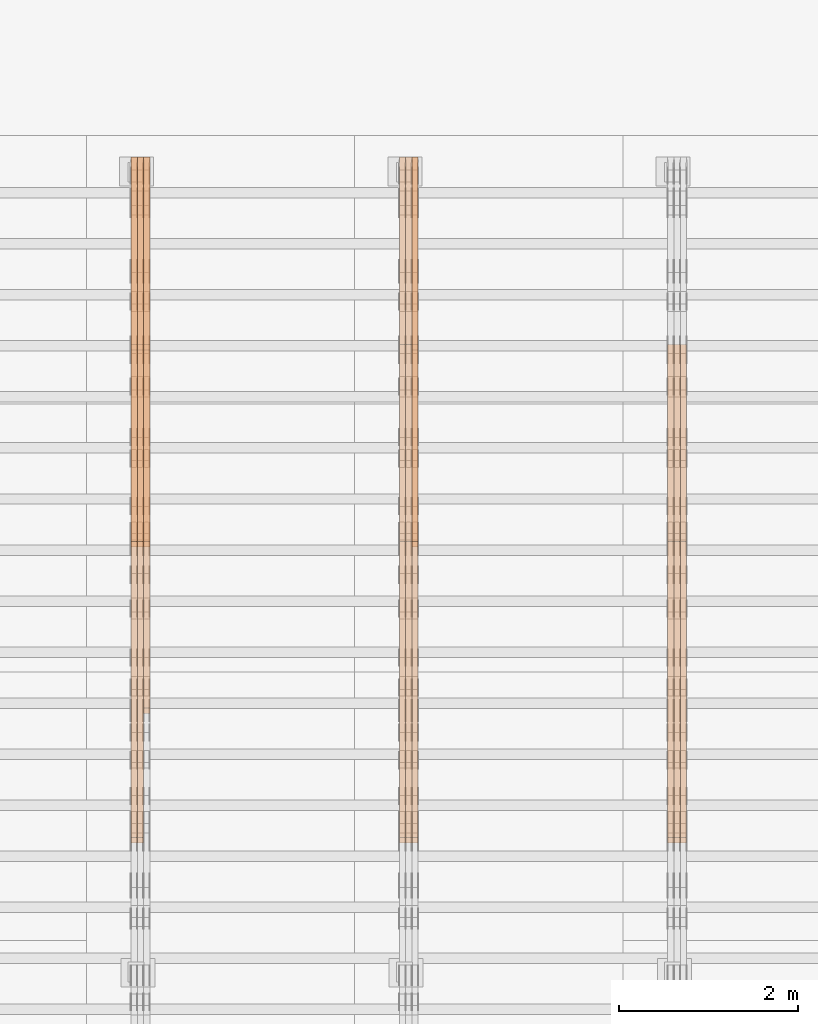
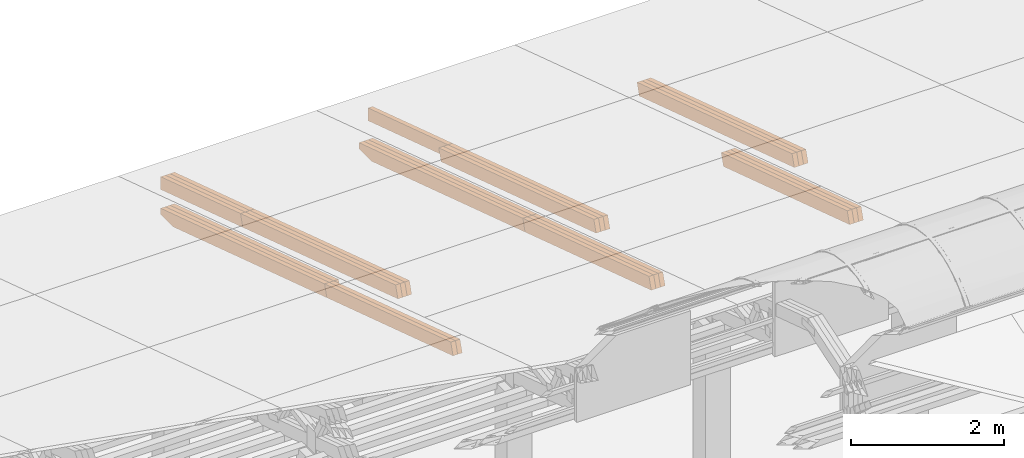
# One storey, part 23 of 385: 27 proxies.
"""IFC2X3 building model written with IfcOpenShell, lengths in millimetres."""

from ifc_helpers import new_model, entity, si_unit, converted_unit, derived_unit, direction, frame, origin, place, context, subcontext, project, spatial, polyline, outline, extrude, source, transform, mapped, material, type_object, type_shapes, element, save


model = new_model("IFC2X3")

# Units and contexts
model_context = context("Model", 3, precision=0.01, world=origin(), true_north=direction((6.12303176911189e-17, 1.0)))
body_context = subcontext(model_context, "Body", "Model", "MODEL_VIEW")
ifc_project = project(units=[si_unit("LENGTHUNIT", "METRE", prefix="MILLI"), si_unit("AREAUNIT", "SQUARE_METRE"), si_unit("VOLUMEUNIT", "CUBIC_METRE"), converted_unit("PLANEANGLEUNIT", "DEGREE", entity("IfcRatioMeasure", 0.0174532925199433), si_unit("PLANEANGLEUNIT", "RADIAN"), dimensions=[0, 0, 0, 0, 0, 0, 0]), si_unit("MASSUNIT", "GRAM", prefix="KILO"), derived_unit("MASSDENSITYUNIT", [(si_unit("MASSUNIT", "GRAM", prefix="KILO"), 1), (si_unit("LENGTHUNIT", "METRE"), -3)]), si_unit("TIMEUNIT", "SECOND"), si_unit("FREQUENCYUNIT", "HERTZ"), si_unit("THERMODYNAMICTEMPERATUREUNIT", "DEGREE_CELSIUS"), derived_unit("THERMALTRANSMITTANCEUNIT", [(si_unit("MASSUNIT", "GRAM", prefix="KILO"), 1), (si_unit("THERMODYNAMICTEMPERATUREUNIT", "KELVIN"), -1), (si_unit("TIMEUNIT", "SECOND"), -3)]), derived_unit("VOLUMETRICFLOWRATEUNIT", [(si_unit("LENGTHUNIT", "METRE"), 3), (si_unit("TIMEUNIT", "SECOND"), -1)]), si_unit("ELECTRICCURRENTUNIT", "AMPERE"), si_unit("ELECTRICVOLTAGEUNIT", "VOLT"), si_unit("POWERUNIT", "WATT"), si_unit("FORCEUNIT", "NEWTON", prefix="KILO"), si_unit("ILLUMINANCEUNIT", "LUX"), si_unit("LUMINOUSFLUXUNIT", "LUMEN"), si_unit("LUMINOUSINTENSITYUNIT", "CANDELA"), derived_unit("USERDEFINED", [(si_unit("MASSUNIT", "GRAM", prefix="KILO"), -1), (si_unit("LENGTHUNIT", "METRE"), -2), (si_unit("TIMEUNIT", "SECOND"), 3), (si_unit("LUMINOUSFLUXUNIT", "LUMEN"), 1)]), derived_unit("LINEARVELOCITYUNIT", [(si_unit("LENGTHUNIT", "METRE"), 1), (si_unit("TIMEUNIT", "SECOND"), -1)]), si_unit("PRESSUREUNIT", "PASCAL"), derived_unit("USERDEFINED", [(si_unit("LENGTHUNIT", "METRE"), -2), (si_unit("MASSUNIT", "GRAM", prefix="KILO"), 1), (si_unit("TIMEUNIT", "SECOND"), -2)])], contexts=[model_context])

# Site, building, storey
site_placement = place(None, origin())
site = spatial("IfcSite", under=ifc_project, at=site_placement, CompositionType="ELEMENT")
building_placement = place(site_placement, origin())
building = spatial("IfcBuilding", under=site, at=building_placement, CompositionType="ELEMENT")
storey_placement = place(building_placement, origin())
storey = spatial("IfcBuildingStorey", under=building, at=storey_placement, Name="Default", CompositionType="ELEMENT", Elevation=0.0)

# Proxies
ifc_material_1 = material(Name="IfcSurfaceStyle #352509")
building_element_proxy_type_1 = type_object("IfcBuildingElementProxyType", Name="T1-T2 352507", PredefinedType="NOTDEFINED", material=ifc_material_1)
shared_shape_1 = source(origin(), body_context, "Body", "SweptSolid", [
    extrude(outline(polyline([(-2137.04373183812, -97.5000250291418), (2137.04394104036, -97.5000250291418), (2137.04396402965, 97.5000250291418), (-2137.04417323189, 97.5000250291418), (-2137.04373183812, -97.5000250291418)])), frame((2137.04396402965, 97.5001541485632, 0.0), z_axis=(0.0, 0.0, 1.0), x_axis=(-1.0, 0.0, 0.0)), (0.0, 0.0, 1.0), 69.9999999999997),
])
type_shapes(building_element_proxy_type_1, [shared_shape_1])
proxy_1_placement = place(building_placement, frame((30385.0, 24344.7841397874, 1095.2368156767), z_axis=(-1.0, 0.0, 0.0), x_axis=(0.0, -0.951056516295154, 0.309016994374948)))
element("IfcBuildingElementProxy", 1, at=proxy_1_placement, inside=storey, type_object=building_element_proxy_type_1, material=ifc_material_1, Name="T1-T2", context=body_context, shape_type="MappedRepresentation", body=[
    mapped(shared_shape_1, transform((0.0, 0.0, 0.0), scale=1.0)),
])
ifc_material_2 = material(Name="IfcSurfaceStyle #352452")
building_element_proxy_type_2 = type_object("IfcBuildingElementProxyType", Name="T1-T2 352450", PredefinedType="NOTDEFINED", material=ifc_material_2)
shared_shape_2 = source(origin(), body_context, "Body", "SweptSolid", [
    extrude(outline(polyline([(-2137.04373183812, -97.5000250291418), (2137.04394104036, -97.5000250291418), (2137.04396402965, 97.5000250291418), (-2137.04417323189, 97.5000250291418), (-2137.04373183812, -97.5000250291418)])), frame((2137.04396402965, 97.5001541485632, 0.0), z_axis=(0.0, 0.0, 1.0), x_axis=(-1.0, 0.0, 0.0)), (0.0, 0.0, 1.0), 69.9999999999997),
])
type_shapes(building_element_proxy_type_2, [shared_shape_2])
proxy_2_placement = place(building_placement, frame((30315.0, 24344.7841397874, 1095.2368156767), z_axis=(-1.0, 0.0, 0.0), x_axis=(0.0, -0.951056516295154, 0.309016994374948)))
element("IfcBuildingElementProxy", 2, at=proxy_2_placement, inside=storey, type_object=building_element_proxy_type_2, material=ifc_material_2, Name="T1-T2", context=body_context, shape_type="MappedRepresentation", body=[
    mapped(shared_shape_2, transform((0.0, 0.0, 0.0), scale=1.0)),
])
ifc_material_3 = material(Name="IfcSurfaceStyle #352395")
building_element_proxy_type_3 = type_object("IfcBuildingElementProxyType", Name="T1-T2 352393", PredefinedType="NOTDEFINED", material=ifc_material_3)
shared_shape_3 = source(origin(), body_context, "Body", "SweptSolid", [
    extrude(outline(polyline([(-2137.04373183812, -97.5000250291418), (2137.04394104036, -97.5000250291418), (2137.04396402965, 97.5000250291418), (-2137.04417323189, 97.5000250291418), (-2137.04373183812, -97.5000250291418)])), frame((2137.04396402965, 97.5001541485632, 0.0), z_axis=(0.0, 0.0, 1.0), x_axis=(-1.0, 0.0, 0.0)), (0.0, 0.0, 1.0), 69.9999999999997),
])
type_shapes(building_element_proxy_type_3, [shared_shape_3])
proxy_3_placement = place(building_placement, frame((30245.0, 24344.7841397874, 1095.2368156767), z_axis=(-1.0, 0.0, 0.0), x_axis=(0.0, -0.951056516295154, 0.309016994374948)))
element("IfcBuildingElementProxy", 3, at=proxy_3_placement, inside=storey, type_object=building_element_proxy_type_3, material=ifc_material_3, Name="T1-T2", context=body_context, shape_type="MappedRepresentation", body=[
    mapped(shared_shape_3, transform((0.0, 0.0, 0.0), scale=1.0)),
])
ifc_material_4 = material(Name="IfcSurfaceStyle #351114")
building_element_proxy_type_4 = type_object("IfcBuildingElementProxyType", Name="T1-B2 351112", PredefinedType="NOTDEFINED", material=ifc_material_4)
shared_shape_4 = source(origin(), body_context, "Body", "SweptSolid", [
    extrude(outline(polyline([(-1738.61933402934, -97.4999466901035), (1738.6190788485, -97.4999466901035), (1738.6191018378, 97.4999466901035), (-1738.61884665697, 97.4999466901035), (-1738.61933402934, -97.4999466901035)])), frame((1738.6191018378, 97.4999528847471, 0.0), z_axis=(0.0, 0.0, 1.0), x_axis=(-1.0, 0.0, 0.0)), (0.0, 0.0, 1.0), 69.9999999999998),
])
type_shapes(building_element_proxy_type_4, [shared_shape_4])
proxy_4_placement = place(building_placement, frame((30385.0, 22140.4521465233, 1306.03026754604), z_axis=(-1.0, 0.0, 0.0), x_axis=(0.0, -0.951056516295124, 0.309016994375039)))
element("IfcBuildingElementProxy", 4, at=proxy_4_placement, inside=storey, type_object=building_element_proxy_type_4, material=ifc_material_4, Name="T1-B2", context=body_context, shape_type="MappedRepresentation", body=[
    mapped(shared_shape_4, transform((0.0, 0.0, 0.0), scale=1.0)),
])
ifc_material_5 = material(Name="IfcSurfaceStyle #351057")
building_element_proxy_type_5 = type_object("IfcBuildingElementProxyType", Name="T1-B2 351055", PredefinedType="NOTDEFINED", material=ifc_material_5)
shared_shape_5 = source(origin(), body_context, "Body", "SweptSolid", [
    extrude(outline(polyline([(-1738.61933402934, -97.4999466901035), (1738.6190788485, -97.4999466901035), (1738.6191018378, 97.4999466901035), (-1738.61884665697, 97.4999466901035), (-1738.61933402934, -97.4999466901035)])), frame((1738.6191018378, 97.4999528847471, 0.0), z_axis=(0.0, 0.0, 1.0), x_axis=(-1.0, 0.0, 0.0)), (0.0, 0.0, 1.0), 69.9999999999998),
])
type_shapes(building_element_proxy_type_5, [shared_shape_5])
proxy_5_placement = place(building_placement, frame((30315.0, 22140.4521465233, 1306.03026754604), z_axis=(-1.0, 0.0, 0.0), x_axis=(0.0, -0.951056516295124, 0.309016994375039)))
element("IfcBuildingElementProxy", 5, at=proxy_5_placement, inside=storey, type_object=building_element_proxy_type_5, material=ifc_material_5, Name="T1-B2", context=body_context, shape_type="MappedRepresentation", body=[
    mapped(shared_shape_5, transform((0.0, 0.0, 0.0), scale=1.0)),
])
ifc_material_6 = material(Name="IfcSurfaceStyle #351000")
building_element_proxy_type_6 = type_object("IfcBuildingElementProxyType", Name="T1-B2 350998", PredefinedType="NOTDEFINED", material=ifc_material_6)
shared_shape_6 = source(origin(), body_context, "Body", "SweptSolid", [
    extrude(outline(polyline([(-1738.61933402934, -97.4999466901035), (1738.6190788485, -97.4999466901035), (1738.6191018378, 97.4999466901035), (-1738.61884665697, 97.4999466901035), (-1738.61933402934, -97.4999466901035)])), frame((1738.6191018378, 97.4999528847471, 0.0), z_axis=(0.0, 0.0, 1.0), x_axis=(-1.0, 0.0, 0.0)), (0.0, 0.0, 1.0), 69.9999999999998),
])
type_shapes(building_element_proxy_type_6, [shared_shape_6])
proxy_6_placement = place(building_placement, frame((30245.0, 22140.4521465233, 1306.03026754604), z_axis=(-1.0, 0.0, 0.0), x_axis=(0.0, -0.951056516295124, 0.309016994375039)))
element("IfcBuildingElementProxy", 6, at=proxy_6_placement, inside=storey, type_object=building_element_proxy_type_6, material=ifc_material_6, Name="T1-B2", context=body_context, shape_type="MappedRepresentation", body=[
    mapped(shared_shape_6, transform((0.0, 0.0, 0.0), scale=1.0)),
])
ifc_material_7 = material(Name="IfcSurfaceStyle #318077")
building_element_proxy_type_7 = type_object("IfcBuildingElementProxyType", Name="T1-T2 318075", PredefinedType="NOTDEFINED", material=ifc_material_7)
shared_shape_7 = source(origin(), body_context, "Body", "SweptSolid", [
    extrude(outline(polyline([(-2137.04373183812, -97.5000250291418), (2137.04394104036, -97.5000250291418), (2137.04396402965, 97.5000250291418), (-2137.04417323189, 97.5000250291418), (-2137.04373183812, -97.5000250291418)])), frame((2137.04396402965, 97.5001541485632, 0.0), z_axis=(0.0, 0.0, 1.0), x_axis=(-1.0, 0.0, 0.0)), (0.0, 0.0, 1.0), 69.9999999999997),
])
type_shapes(building_element_proxy_type_7, [shared_shape_7])
proxy_7_placement = place(building_placement, frame((27385.0, 24344.7841397874, 1095.2368156767), z_axis=(-1.0, 0.0, 0.0), x_axis=(0.0, -0.951056516295154, 0.309016994374948)))
element("IfcBuildingElementProxy", 7, at=proxy_7_placement, inside=storey, type_object=building_element_proxy_type_7, material=ifc_material_7, Name="T1-T2", context=body_context, shape_type="MappedRepresentation", body=[
    mapped(shared_shape_7, transform((0.0, 0.0, 0.0), scale=1.0)),
])
ifc_material_8 = material(Name="IfcSurfaceStyle #318020")
building_element_proxy_type_8 = type_object("IfcBuildingElementProxyType", Name="T1-T2 318018", PredefinedType="NOTDEFINED", material=ifc_material_8)
shared_shape_8 = source(origin(), body_context, "Body", "SweptSolid", [
    extrude(outline(polyline([(-2137.04373183812, -97.5000250291418), (2137.04394104036, -97.5000250291418), (2137.04396402965, 97.5000250291418), (-2137.04417323189, 97.5000250291418), (-2137.04373183812, -97.5000250291418)])), frame((2137.04396402965, 97.5001541485632, 0.0), z_axis=(0.0, 0.0, 1.0), x_axis=(-1.0, 0.0, 0.0)), (0.0, 0.0, 1.0), 69.9999999999997),
])
type_shapes(building_element_proxy_type_8, [shared_shape_8])
proxy_8_placement = place(building_placement, frame((27315.0, 24344.7841397874, 1095.2368156767), z_axis=(-1.0, 0.0, 0.0), x_axis=(0.0, -0.951056516295154, 0.309016994374948)))
element("IfcBuildingElementProxy", 8, at=proxy_8_placement, inside=storey, type_object=building_element_proxy_type_8, material=ifc_material_8, Name="T1-T2", context=body_context, shape_type="MappedRepresentation", body=[
    mapped(shared_shape_8, transform((0.0, 0.0, 0.0), scale=1.0)),
])
ifc_material_9 = material(Name="IfcSurfaceStyle #317963")
building_element_proxy_type_9 = type_object("IfcBuildingElementProxyType", Name="T1-T2 317961", PredefinedType="NOTDEFINED", material=ifc_material_9)
shared_shape_9 = source(origin(), body_context, "Body", "SweptSolid", [
    extrude(outline(polyline([(-2137.04373183812, -97.5000250291418), (2137.04394104036, -97.5000250291418), (2137.04396402965, 97.5000250291418), (-2137.04417323189, 97.5000250291418), (-2137.04373183812, -97.5000250291418)])), frame((2137.04396402965, 97.5001541485632, 0.0), z_axis=(0.0, 0.0, 1.0), x_axis=(-1.0, 0.0, 0.0)), (0.0, 0.0, 1.0), 69.9999999999997),
])
type_shapes(building_element_proxy_type_9, [shared_shape_9])
proxy_9_placement = place(building_placement, frame((27245.0, 24344.7841397874, 1095.2368156767), z_axis=(-1.0, 0.0, 0.0), x_axis=(0.0, -0.951056516295154, 0.309016994374948)))
element("IfcBuildingElementProxy", 9, at=proxy_9_placement, inside=storey, type_object=building_element_proxy_type_9, material=ifc_material_9, Name="T1-T2", context=body_context, shape_type="MappedRepresentation", body=[
    mapped(shared_shape_9, transform((0.0, 0.0, 0.0), scale=1.0)),
])
ifc_material_10 = material(Name="IfcSurfaceStyle #317906")
building_element_proxy_type_10 = type_object("IfcBuildingElementProxyType", Name="T1-T3 317904", PredefinedType="NOTDEFINED", material=ifc_material_10)
shared_shape_10 = source(origin(), body_context, "Body", "SweptSolid", [
    extrude(outline(polyline([(-1117.22419189679, -97.5000115568039), (1085.54451125458, -97.5000115568039), (1148.90384954971, 97.5000115568039), (-1117.2241689075, 97.5000115568039), (-1117.22419189679, -97.5000115568039)])), frame((1148.90385201956, 97.5000191595882, 0.0), z_axis=(0.0, 0.0, 1.0), x_axis=(-1.0, 0.0, 0.0)), (0.0, 0.0, 1.0), 69.9999999999999),
])
type_shapes(building_element_proxy_type_10, [shared_shape_10])
proxy_10_placement = place(building_placement, frame((27385.0, 26500.0, 394.964866273674), z_axis=(-1.0, 0.0, 0.0), x_axis=(0.0, -0.951056516295154, 0.309016994374948)))
element("IfcBuildingElementProxy", 10, at=proxy_10_placement, inside=storey, type_object=building_element_proxy_type_10, material=ifc_material_10, Name="T1-T3", context=body_context, shape_type="MappedRepresentation", body=[
    mapped(shared_shape_10, transform((0.0, 0.0, 0.0), scale=1.0)),
])
ifc_material_11 = material(Name="IfcSurfaceStyle #316682")
building_element_proxy_type_11 = type_object("IfcBuildingElementProxyType", Name="T1-B2 316680", PredefinedType="NOTDEFINED", material=ifc_material_11)
shared_shape_11 = source(origin(), body_context, "Body", "SweptSolid", [
    extrude(outline(polyline([(-1738.61933402934, -97.4999466901035), (1738.6190788485, -97.4999466901035), (1738.6191018378, 97.4999466901035), (-1738.61884665697, 97.4999466901035), (-1738.61933402934, -97.4999466901035)])), frame((1738.6191018378, 97.4999528847471, 0.0), z_axis=(0.0, 0.0, 1.0), x_axis=(-1.0, 0.0, 0.0)), (0.0, 0.0, 1.0), 69.9999999999998),
])
type_shapes(building_element_proxy_type_11, [shared_shape_11])
proxy_11_placement = place(building_placement, frame((27385.0, 22140.4521465233, 1306.03026754604), z_axis=(-1.0, 0.0, 0.0), x_axis=(0.0, -0.951056516295124, 0.309016994375039)))
element("IfcBuildingElementProxy", 11, at=proxy_11_placement, inside=storey, type_object=building_element_proxy_type_11, material=ifc_material_11, Name="T1-B2", context=body_context, shape_type="MappedRepresentation", body=[
    mapped(shared_shape_11, transform((0.0, 0.0, 0.0), scale=1.0)),
])
ifc_material_12 = material(Name="IfcSurfaceStyle #316625")
building_element_proxy_type_12 = type_object("IfcBuildingElementProxyType", Name="T1-B2 316623", PredefinedType="NOTDEFINED", material=ifc_material_12)
shared_shape_12 = source(origin(), body_context, "Body", "SweptSolid", [
    extrude(outline(polyline([(-1738.61933402934, -97.4999466901035), (1738.6190788485, -97.4999466901035), (1738.6191018378, 97.4999466901035), (-1738.61884665697, 97.4999466901035), (-1738.61933402934, -97.4999466901035)])), frame((1738.6191018378, 97.4999528847471, 0.0), z_axis=(0.0, 0.0, 1.0), x_axis=(-1.0, 0.0, 0.0)), (0.0, 0.0, 1.0), 69.9999999999998),
])
type_shapes(building_element_proxy_type_12, [shared_shape_12])
proxy_12_placement = place(building_placement, frame((27315.0, 22140.4521465233, 1306.03026754604), z_axis=(-1.0, 0.0, 0.0), x_axis=(0.0, -0.951056516295124, 0.309016994375039)))
element("IfcBuildingElementProxy", 12, at=proxy_12_placement, inside=storey, type_object=building_element_proxy_type_12, material=ifc_material_12, Name="T1-B2", context=body_context, shape_type="MappedRepresentation", body=[
    mapped(shared_shape_12, transform((0.0, 0.0, 0.0), scale=1.0)),
])
ifc_material_13 = material(Name="IfcSurfaceStyle #316568")
building_element_proxy_type_13 = type_object("IfcBuildingElementProxyType", Name="T1-B2 316566", PredefinedType="NOTDEFINED", material=ifc_material_13)
shared_shape_13 = source(origin(), body_context, "Body", "SweptSolid", [
    extrude(outline(polyline([(-1738.61933402934, -97.4999466901035), (1738.6190788485, -97.4999466901035), (1738.6191018378, 97.4999466901035), (-1738.61884665697, 97.4999466901035), (-1738.61933402934, -97.4999466901035)])), frame((1738.6191018378, 97.4999528847471, 0.0), z_axis=(0.0, 0.0, 1.0), x_axis=(-1.0, 0.0, 0.0)), (0.0, 0.0, 1.0), 69.9999999999998),
])
type_shapes(building_element_proxy_type_13, [shared_shape_13])
proxy_13_placement = place(building_placement, frame((27245.0, 22140.4521465233, 1306.03026754604), z_axis=(-1.0, 0.0, 0.0), x_axis=(0.0, -0.951056516295124, 0.309016994375039)))
element("IfcBuildingElementProxy", 13, at=proxy_13_placement, inside=storey, type_object=building_element_proxy_type_13, material=ifc_material_13, Name="T1-B2", context=body_context, shape_type="MappedRepresentation", body=[
    mapped(shared_shape_13, transform((0.0, 0.0, 0.0), scale=1.0)),
])
ifc_material_14 = material(Name="IfcSurfaceStyle #316511")
building_element_proxy_type_14 = type_object("IfcBuildingElementProxyType", Name="T1-B1 316509", PredefinedType="NOTDEFINED", material=ifc_material_14)
shared_shape_14 = source(origin(), body_context, "Body", "SweptSolid", [
    extrude(outline(polyline([(-2659.34106034305, -95.9868650736445), (1861.19950396595, -95.9868650736445), (1890.42090463564, -6.05260867570997), (1567.0616890952, 99.0131694114995), (-2659.34103735375, 99.0131694114995), (-2659.34106034305, -95.9868650736445)])), frame((1890.42090463564, 99.013169411504, 0.0), z_axis=(0.0, 0.0, 1.0), x_axis=(-1.0, 0.0, 0.0)), (0.0, 0.0, 1.0), 69.9999999999997),
])
type_shapes(building_element_proxy_type_14, [shared_shape_14])
proxy_14_placement = place(building_placement, frame((27385.0, 26467.5328890438, -99.9234928894624), z_axis=(-1.0, 0.0, 0.0), x_axis=(0.0, -0.951056516295124, 0.309016994375039)))
element("IfcBuildingElementProxy", 14, at=proxy_14_placement, inside=storey, type_object=building_element_proxy_type_14, material=ifc_material_14, Name="T1-B1", context=body_context, shape_type="MappedRepresentation", body=[
    mapped(shared_shape_14, transform((0.0, 0.0, 0.0), scale=1.0)),
])
ifc_material_15 = material(Name="IfcSurfaceStyle #316445")
building_element_proxy_type_15 = type_object("IfcBuildingElementProxyType", Name="T1-B1 316443", PredefinedType="NOTDEFINED", material=ifc_material_15)
shared_shape_15 = source(origin(), body_context, "Body", "SweptSolid", [
    extrude(outline(polyline([(-2659.34106034305, -95.9868650736445), (1861.19950396595, -95.9868650736445), (1890.42090463564, -6.05260867570997), (1567.0616890952, 99.0131694114995), (-2659.34103735375, 99.0131694114995), (-2659.34106034305, -95.9868650736445)])), frame((1890.42090463564, 99.013169411504, 0.0), z_axis=(0.0, 0.0, 1.0), x_axis=(-1.0, 0.0, 0.0)), (0.0, 0.0, 1.0), 69.9999999999997),
])
type_shapes(building_element_proxy_type_15, [shared_shape_15])
proxy_15_placement = place(building_placement, frame((27315.0, 26467.5328890438, -99.9234928894624), z_axis=(-1.0, 0.0, 0.0), x_axis=(0.0, -0.951056516295124, 0.309016994375039)))
element("IfcBuildingElementProxy", 15, at=proxy_15_placement, inside=storey, type_object=building_element_proxy_type_15, material=ifc_material_15, Name="T1-B1", context=body_context, shape_type="MappedRepresentation", body=[
    mapped(shared_shape_15, transform((0.0, 0.0, 0.0), scale=1.0)),
])
ifc_material_16 = material(Name="IfcSurfaceStyle #316379")
building_element_proxy_type_16 = type_object("IfcBuildingElementProxyType", Name="T1-B1 316377", PredefinedType="NOTDEFINED", material=ifc_material_16)
shared_shape_16 = source(origin(), body_context, "Body", "SweptSolid", [
    extrude(outline(polyline([(-2659.34106034305, -95.9868650736445), (1861.19950396595, -95.9868650736445), (1890.42090463564, -6.05260867570997), (1567.0616890952, 99.0131694114995), (-2659.34103735375, 99.0131694114995), (-2659.34106034305, -95.9868650736445)])), frame((1890.42090463564, 99.013169411504, 0.0), z_axis=(0.0, 0.0, 1.0), x_axis=(-1.0, 0.0, 0.0)), (0.0, 0.0, 1.0), 69.9999999999997),
])
type_shapes(building_element_proxy_type_16, [shared_shape_16])
proxy_16_placement = place(building_placement, frame((27245.0, 26467.5328890438, -99.9234928894624), z_axis=(-1.0, 0.0, 0.0), x_axis=(0.0, -0.951056516295124, 0.309016994375039)))
element("IfcBuildingElementProxy", 16, at=proxy_16_placement, inside=storey, type_object=building_element_proxy_type_16, material=ifc_material_16, Name="T1-B1", context=body_context, shape_type="MappedRepresentation", body=[
    mapped(shared_shape_16, transform((0.0, 0.0, 0.0), scale=1.0)),
])
ifc_material_17 = material(Name="IfcSurfaceStyle #283645")
building_element_proxy_type_17 = type_object("IfcBuildingElementProxyType", Name="T1-T2 283643", PredefinedType="NOTDEFINED", material=ifc_material_17)
shared_shape_17 = source(origin(), body_context, "Body", "SweptSolid", [
    extrude(outline(polyline([(-2137.04373183812, -97.5000250291418), (2137.04394104036, -97.5000250291418), (2137.04396402965, 97.5000250291418), (-2137.04417323189, 97.5000250291418), (-2137.04373183812, -97.5000250291418)])), frame((2137.04396402965, 97.5001541485632, 0.0), z_axis=(0.0, 0.0, 1.0), x_axis=(-1.0, 0.0, 0.0)), (0.0, 0.0, 1.0), 69.9999999999997),
])
type_shapes(building_element_proxy_type_17, [shared_shape_17])
proxy_17_placement = place(building_placement, frame((24385.0, 24344.7841397874, 1095.2368156767), z_axis=(-1.0, 0.0, 0.0), x_axis=(0.0, -0.951056516295154, 0.309016994374948)))
element("IfcBuildingElementProxy", 17, at=proxy_17_placement, inside=storey, type_object=building_element_proxy_type_17, material=ifc_material_17, Name="T1-T2", context=body_context, shape_type="MappedRepresentation", body=[
    mapped(shared_shape_17, transform((0.0, 0.0, 0.0), scale=1.0)),
])
ifc_material_18 = material(Name="IfcSurfaceStyle #283588")
building_element_proxy_type_18 = type_object("IfcBuildingElementProxyType", Name="T1-T2 283586", PredefinedType="NOTDEFINED", material=ifc_material_18)
shared_shape_18 = source(origin(), body_context, "Body", "SweptSolid", [
    extrude(outline(polyline([(-2137.04373183812, -97.5000250291418), (2137.04394104036, -97.5000250291418), (2137.04396402965, 97.5000250291418), (-2137.04417323189, 97.5000250291418), (-2137.04373183812, -97.5000250291418)])), frame((2137.04396402965, 97.5001541485632, 0.0), z_axis=(0.0, 0.0, 1.0), x_axis=(-1.0, 0.0, 0.0)), (0.0, 0.0, 1.0), 69.9999999999997),
])
type_shapes(building_element_proxy_type_18, [shared_shape_18])
proxy_18_placement = place(building_placement, frame((24315.0, 24344.7841397874, 1095.2368156767), z_axis=(-1.0, 0.0, 0.0), x_axis=(0.0, -0.951056516295154, 0.309016994374948)))
element("IfcBuildingElementProxy", 18, at=proxy_18_placement, inside=storey, type_object=building_element_proxy_type_18, material=ifc_material_18, Name="T1-T2", context=body_context, shape_type="MappedRepresentation", body=[
    mapped(shared_shape_18, transform((0.0, 0.0, 0.0), scale=1.0)),
])
ifc_material_19 = material(Name="IfcSurfaceStyle #283531")
building_element_proxy_type_19 = type_object("IfcBuildingElementProxyType", Name="T1-T2 283529", PredefinedType="NOTDEFINED", material=ifc_material_19)
shared_shape_19 = source(origin(), body_context, "Body", "SweptSolid", [
    extrude(outline(polyline([(-2137.04373183812, -97.5000250291418), (2137.04394104036, -97.5000250291418), (2137.04396402965, 97.5000250291418), (-2137.04417323189, 97.5000250291418), (-2137.04373183812, -97.5000250291418)])), frame((2137.04396402965, 97.5001541485632, 0.0), z_axis=(0.0, 0.0, 1.0), x_axis=(-1.0, 0.0, 0.0)), (0.0, 0.0, 1.0), 69.9999999999997),
])
type_shapes(building_element_proxy_type_19, [shared_shape_19])
proxy_19_placement = place(building_placement, frame((24245.0, 24344.7841397874, 1095.2368156767), z_axis=(-1.0, 0.0, 0.0), x_axis=(0.0, -0.951056516295154, 0.309016994374948)))
element("IfcBuildingElementProxy", 19, at=proxy_19_placement, inside=storey, type_object=building_element_proxy_type_19, material=ifc_material_19, Name="T1-T2", context=body_context, shape_type="MappedRepresentation", body=[
    mapped(shared_shape_19, transform((0.0, 0.0, 0.0), scale=1.0)),
])
ifc_material_20 = material(Name="IfcSurfaceStyle #283474")
building_element_proxy_type_20 = type_object("IfcBuildingElementProxyType", Name="T1-T3 283472", PredefinedType="NOTDEFINED", material=ifc_material_20)
shared_shape_20 = source(origin(), body_context, "Body", "SweptSolid", [
    extrude(outline(polyline([(-1117.22419189679, -97.5000115568039), (1085.54451125458, -97.5000115568039), (1148.90384954971, 97.5000115568039), (-1117.2241689075, 97.5000115568039), (-1117.22419189679, -97.5000115568039)])), frame((1148.90385201956, 97.5000191595882, 0.0), z_axis=(0.0, 0.0, 1.0), x_axis=(-1.0, 0.0, 0.0)), (0.0, 0.0, 1.0), 69.9999999999999),
])
type_shapes(building_element_proxy_type_20, [shared_shape_20])
proxy_20_placement = place(building_placement, frame((24385.0, 26500.0, 394.964866273674), z_axis=(-1.0, 0.0, 0.0), x_axis=(0.0, -0.951056516295154, 0.309016994374948)))
element("IfcBuildingElementProxy", 20, at=proxy_20_placement, inside=storey, type_object=building_element_proxy_type_20, material=ifc_material_20, Name="T1-T3", context=body_context, shape_type="MappedRepresentation", body=[
    mapped(shared_shape_20, transform((0.0, 0.0, 0.0), scale=1.0)),
])
ifc_material_21 = material(Name="IfcSurfaceStyle #283417")
building_element_proxy_type_21 = type_object("IfcBuildingElementProxyType", Name="T1-T3 283415", PredefinedType="NOTDEFINED", material=ifc_material_21)
shared_shape_21 = source(origin(), body_context, "Body", "SweptSolid", [
    extrude(outline(polyline([(-1117.22419189679, -97.5000115568039), (1085.54451125458, -97.5000115568039), (1148.90384954971, 97.5000115568039), (-1117.2241689075, 97.5000115568039), (-1117.22419189679, -97.5000115568039)])), frame((1148.90385201956, 97.5000191595882, 0.0), z_axis=(0.0, 0.0, 1.0), x_axis=(-1.0, 0.0, 0.0)), (0.0, 0.0, 1.0), 69.9999999999999),
])
type_shapes(building_element_proxy_type_21, [shared_shape_21])
proxy_21_placement = place(building_placement, frame((24315.0, 26500.0, 394.964866273674), z_axis=(-1.0, 0.0, 0.0), x_axis=(0.0, -0.951056516295154, 0.309016994374948)))
element("IfcBuildingElementProxy", 21, at=proxy_21_placement, inside=storey, type_object=building_element_proxy_type_21, material=ifc_material_21, Name="T1-T3", context=body_context, shape_type="MappedRepresentation", body=[
    mapped(shared_shape_21, transform((0.0, 0.0, 0.0), scale=1.0)),
])
ifc_material_22 = material(Name="IfcSurfaceStyle #283360")
building_element_proxy_type_22 = type_object("IfcBuildingElementProxyType", Name="T1-T3 283358", PredefinedType="NOTDEFINED", material=ifc_material_22)
shared_shape_22 = source(origin(), body_context, "Body", "SweptSolid", [
    extrude(outline(polyline([(-1117.22419189679, -97.5000115568039), (1085.54451125458, -97.5000115568039), (1148.90384954971, 97.5000115568039), (-1117.2241689075, 97.5000115568039), (-1117.22419189679, -97.5000115568039)])), frame((1148.90385201956, 97.5000191595882, 0.0), z_axis=(0.0, 0.0, 1.0), x_axis=(-1.0, 0.0, 0.0)), (0.0, 0.0, 1.0), 69.9999999999999),
])
type_shapes(building_element_proxy_type_22, [shared_shape_22])
proxy_22_placement = place(building_placement, frame((24245.0, 26500.0, 394.964866273674), z_axis=(-1.0, 0.0, 0.0), x_axis=(0.0, -0.951056516295154, 0.309016994374948)))
element("IfcBuildingElementProxy", 22, at=proxy_22_placement, inside=storey, type_object=building_element_proxy_type_22, material=ifc_material_22, Name="T1-T3", context=body_context, shape_type="MappedRepresentation", body=[
    mapped(shared_shape_22, transform((0.0, 0.0, 0.0), scale=1.0)),
])
ifc_material_23 = material(Name="IfcSurfaceStyle #282193")
building_element_proxy_type_23 = type_object("IfcBuildingElementProxyType", Name="T1-B2 282191", PredefinedType="NOTDEFINED", material=ifc_material_23)
shared_shape_23 = source(origin(), body_context, "Body", "SweptSolid", [
    extrude(outline(polyline([(-1738.61933402934, -97.4999466901035), (1738.6190788485, -97.4999466901035), (1738.6191018378, 97.4999466901035), (-1738.61884665697, 97.4999466901035), (-1738.61933402934, -97.4999466901035)])), frame((1738.6191018378, 97.4999528847471, 0.0), z_axis=(0.0, 0.0, 1.0), x_axis=(-1.0, 0.0, 0.0)), (0.0, 0.0, 1.0), 69.9999999999998),
])
type_shapes(building_element_proxy_type_23, [shared_shape_23])
proxy_23_placement = place(building_placement, frame((24315.0, 22140.4521465233, 1306.03026754604), z_axis=(-1.0, 0.0, 0.0), x_axis=(0.0, -0.951056516295124, 0.309016994375039)))
element("IfcBuildingElementProxy", 23, at=proxy_23_placement, inside=storey, type_object=building_element_proxy_type_23, material=ifc_material_23, Name="T1-B2", context=body_context, shape_type="MappedRepresentation", body=[
    mapped(shared_shape_23, transform((0.0, 0.0, 0.0), scale=1.0)),
])
ifc_material_24 = material(Name="IfcSurfaceStyle #282136")
building_element_proxy_type_24 = type_object("IfcBuildingElementProxyType", Name="T1-B2 282134", PredefinedType="NOTDEFINED", material=ifc_material_24)
shared_shape_24 = source(origin(), body_context, "Body", "SweptSolid", [
    extrude(outline(polyline([(-1738.61933402934, -97.4999466901035), (1738.6190788485, -97.4999466901035), (1738.6191018378, 97.4999466901035), (-1738.61884665697, 97.4999466901035), (-1738.61933402934, -97.4999466901035)])), frame((1738.6191018378, 97.4999528847471, 0.0), z_axis=(0.0, 0.0, 1.0), x_axis=(-1.0, 0.0, 0.0)), (0.0, 0.0, 1.0), 69.9999999999998),
])
type_shapes(building_element_proxy_type_24, [shared_shape_24])
proxy_24_placement = place(building_placement, frame((24245.0, 22140.4521465233, 1306.03026754604), z_axis=(-1.0, 0.0, 0.0), x_axis=(0.0, -0.951056516295124, 0.309016994375039)))
element("IfcBuildingElementProxy", 24, at=proxy_24_placement, inside=storey, type_object=building_element_proxy_type_24, material=ifc_material_24, Name="T1-B2", context=body_context, shape_type="MappedRepresentation", body=[
    mapped(shared_shape_24, transform((0.0, 0.0, 0.0), scale=1.0)),
])
ifc_material_25 = material(Name="IfcSurfaceStyle #282079")
building_element_proxy_type_25 = type_object("IfcBuildingElementProxyType", Name="T1-B1 282077", PredefinedType="NOTDEFINED", material=ifc_material_25)
shared_shape_25 = source(origin(), body_context, "Body", "SweptSolid", [
    extrude(outline(polyline([(-2659.34106034305, -95.9868650736445), (1861.19950396595, -95.9868650736445), (1890.42090463564, -6.05260867570997), (1567.0616890952, 99.0131694114995), (-2659.34103735375, 99.0131694114995), (-2659.34106034305, -95.9868650736445)])), frame((1890.42090463564, 99.013169411504, 0.0), z_axis=(0.0, 0.0, 1.0), x_axis=(-1.0, 0.0, 0.0)), (0.0, 0.0, 1.0), 69.9999999999997),
])
type_shapes(building_element_proxy_type_25, [shared_shape_25])
proxy_25_placement = place(building_placement, frame((24385.0, 26467.5328890438, -99.9234928894624), z_axis=(-1.0, 0.0, 0.0), x_axis=(0.0, -0.951056516295124, 0.309016994375039)))
element("IfcBuildingElementProxy", 25, at=proxy_25_placement, inside=storey, type_object=building_element_proxy_type_25, material=ifc_material_25, Name="T1-B1", context=body_context, shape_type="MappedRepresentation", body=[
    mapped(shared_shape_25, transform((0.0, 0.0, 0.0), scale=1.0)),
])
ifc_material_26 = material(Name="IfcSurfaceStyle #282013")
building_element_proxy_type_26 = type_object("IfcBuildingElementProxyType", Name="T1-B1 282011", PredefinedType="NOTDEFINED", material=ifc_material_26)
shared_shape_26 = source(origin(), body_context, "Body", "SweptSolid", [
    extrude(outline(polyline([(-2659.34106034305, -95.9868650736445), (1861.19950396595, -95.9868650736445), (1890.42090463564, -6.05260867570997), (1567.0616890952, 99.0131694114995), (-2659.34103735375, 99.0131694114995), (-2659.34106034305, -95.9868650736445)])), frame((1890.42090463564, 99.013169411504, 0.0), z_axis=(0.0, 0.0, 1.0), x_axis=(-1.0, 0.0, 0.0)), (0.0, 0.0, 1.0), 69.9999999999997),
])
type_shapes(building_element_proxy_type_26, [shared_shape_26])
proxy_26_placement = place(building_placement, frame((24315.0, 26467.5328890438, -99.9234928894624), z_axis=(-1.0, 0.0, 0.0), x_axis=(0.0, -0.951056516295124, 0.309016994375039)))
element("IfcBuildingElementProxy", 26, at=proxy_26_placement, inside=storey, type_object=building_element_proxy_type_26, material=ifc_material_26, Name="T1-B1", context=body_context, shape_type="MappedRepresentation", body=[
    mapped(shared_shape_26, transform((0.0, 0.0, 0.0), scale=1.0)),
])
ifc_material_27 = material(Name="IfcSurfaceStyle #281947")
building_element_proxy_type_27 = type_object("IfcBuildingElementProxyType", Name="T1-B1 281945", PredefinedType="NOTDEFINED", material=ifc_material_27)
shared_shape_27 = source(origin(), body_context, "Body", "SweptSolid", [
    extrude(outline(polyline([(-2659.34106034305, -95.9868650736445), (1861.19950396595, -95.9868650736445), (1890.42090463564, -6.05260867570997), (1567.0616890952, 99.0131694114995), (-2659.34103735375, 99.0131694114995), (-2659.34106034305, -95.9868650736445)])), frame((1890.42090463564, 99.013169411504, 0.0), z_axis=(0.0, 0.0, 1.0), x_axis=(-1.0, 0.0, 0.0)), (0.0, 0.0, 1.0), 69.9999999999997),
])
type_shapes(building_element_proxy_type_27, [shared_shape_27])
proxy_27_placement = place(building_placement, frame((24245.0, 26467.5328890438, -99.9234928894624), z_axis=(-1.0, 0.0, 0.0), x_axis=(0.0, -0.951056516295124, 0.309016994375039)))
element("IfcBuildingElementProxy", 27, at=proxy_27_placement, inside=storey, type_object=building_element_proxy_type_27, material=ifc_material_27, Name="T1-B1", context=body_context, shape_type="MappedRepresentation", body=[
    mapped(shared_shape_27, transform((0.0, 0.0, 0.0), scale=1.0)),
])

save(model, "model.ifc")
